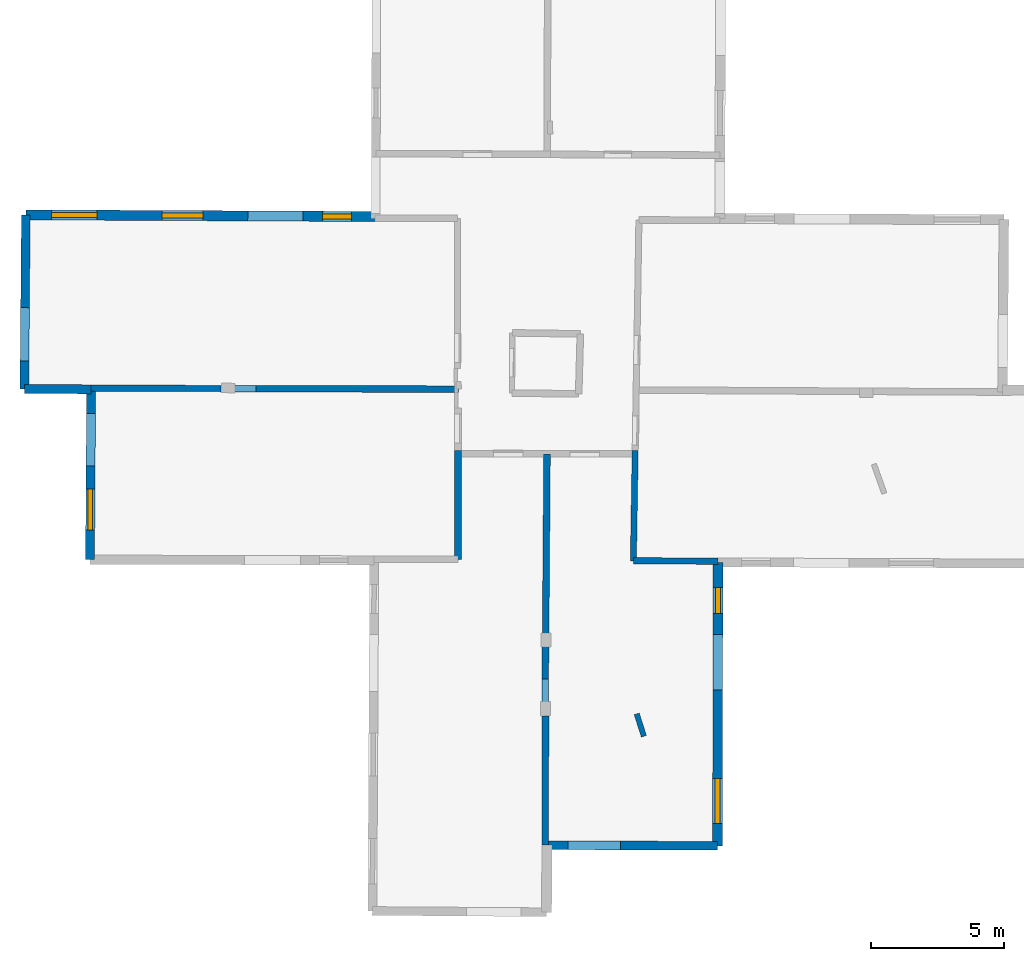
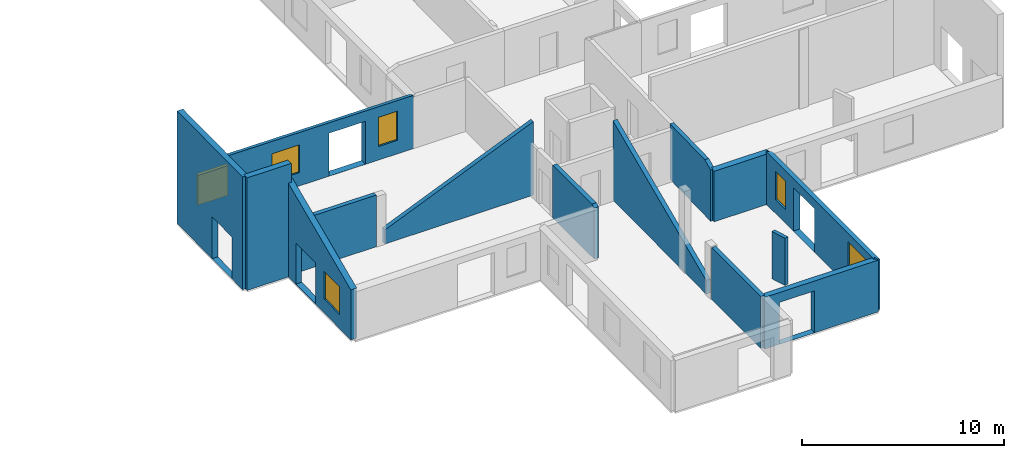
# One storey, part 2 of 10: 14 walls, 6 windows, 11 openings.
"""IFC2X3 building model written with IfcOpenShell, lengths in metres."""

from ifc_helpers import new_model, entity, si_unit, converted_unit, derived_unit, direction, frame, frame_2d, origin, origin_2d_with_axis, place, context, subcontext, project, spatial, polyline, rectangle, outline, extrude, clip, halfspace, source, transform, mapped, material, layer, layer_set, layer_usage, type_object, type_shapes, element, fill, save


model = new_model("IFC2X3")

# Units and contexts
model_context = context("Model", 3, precision=1e-05, world=origin(), true_north=direction((0.0, 1.0)))
body_context = subcontext(model_context, "Body", "Model", "MODEL_VIEW")
ifc_project = project(units=[si_unit("LENGTHUNIT", "METRE"), si_unit("AREAUNIT", "SQUARE_METRE"), si_unit("VOLUMEUNIT", "CUBIC_METRE"), converted_unit("PLANEANGLEUNIT", "DEGREE", entity("IfcRatioMeasure", 0.0174532925199433), si_unit("PLANEANGLEUNIT", "RADIAN"), dimensions=[0, 0, 0, 0, 0, 0, 0]), si_unit("MASSUNIT", "GRAM", prefix="KILO"), derived_unit("MASSDENSITYUNIT", [(si_unit("MASSUNIT", "GRAM", prefix="KILO"), 1), (si_unit("LENGTHUNIT", "METRE"), -3)]), derived_unit("MOMENTOFINERTIAUNIT", [(si_unit("LENGTHUNIT", "METRE"), 4)]), si_unit("TIMEUNIT", "SECOND"), si_unit("FREQUENCYUNIT", "HERTZ"), si_unit("THERMODYNAMICTEMPERATUREUNIT", "DEGREE_CELSIUS"), derived_unit("THERMALTRANSMITTANCEUNIT", [(si_unit("MASSUNIT", "GRAM", prefix="KILO"), 1), (si_unit("THERMODYNAMICTEMPERATUREUNIT", "KELVIN"), -1), (si_unit("TIMEUNIT", "SECOND"), -3)]), derived_unit("VOLUMETRICFLOWRATEUNIT", [(si_unit("LENGTHUNIT", "METRE"), 3), (si_unit("TIMEUNIT", "SECOND"), -1)]), si_unit("ELECTRICCURRENTUNIT", "AMPERE"), si_unit("ELECTRICVOLTAGEUNIT", "VOLT"), si_unit("POWERUNIT", "WATT"), si_unit("FORCEUNIT", "NEWTON", prefix="KILO"), si_unit("ILLUMINANCEUNIT", "LUX"), si_unit("LUMINOUSFLUXUNIT", "LUMEN"), si_unit("LUMINOUSINTENSITYUNIT", "CANDELA"), derived_unit("USERDEFINED", [(si_unit("MASSUNIT", "GRAM", prefix="KILO"), -1), (si_unit("LENGTHUNIT", "METRE"), -2), (si_unit("TIMEUNIT", "SECOND"), 3), (si_unit("LUMINOUSFLUXUNIT", "LUMEN"), 1)]), derived_unit("LINEARVELOCITYUNIT", [(si_unit("LENGTHUNIT", "METRE"), 1), (si_unit("TIMEUNIT", "SECOND"), -1)]), si_unit("PRESSUREUNIT", "PASCAL"), derived_unit("USERDEFINED", [(si_unit("LENGTHUNIT", "METRE"), -2), (si_unit("MASSUNIT", "GRAM", prefix="KILO"), 1), (si_unit("TIMEUNIT", "SECOND"), -2)]), derived_unit("LINEARFORCEUNIT", [(si_unit("MASSUNIT", "GRAM", prefix="KILO"), 1), (si_unit("LENGTHUNIT", "METRE"), 1), (si_unit("TIMEUNIT", "SECOND"), -2), (si_unit("LENGTHUNIT", "METRE"), -1)]), derived_unit("PLANARFORCEUNIT", [(si_unit("MASSUNIT", "GRAM", prefix="KILO"), 1), (si_unit("LENGTHUNIT", "METRE"), 1), (si_unit("TIMEUNIT", "SECOND"), -2), (si_unit("LENGTHUNIT", "METRE"), -2)])], contexts=[model_context])

# Site, building, storey
placement = place(None, origin())
site = spatial("IfcSite", under=ifc_project, at=placement, CompositionType="ELEMENT")
building = spatial("IfcBuilding", under=site, at=placement, CompositionType="ELEMENT")
storey_placement = place(placement, frame((0.0, 0.0, 15.2695512771606)))
storey = spatial("IfcBuildingStorey", under=building, at=storey_placement, Name="Level 6", CompositionType="ELEMENT", Elevation=15.2695512771606)

# Walls
ifc_material_1 = material(Name="Default wall")
ifc_layer_1 = layer(ifc_material_1, 0.25)
ifc_layer_set_1 = layer_set([ifc_layer_1], Name="wall_thickness_0.2500")
ifc_layer_usage_1 = layer_usage(ifc_layer_set_1, "AXIS2", "POSITIVE", -0.125)
wall_type_1 = type_object("IfcWallType", Name="wall_thickness_0.2500", PredefinedType="STANDARD", material=ifc_layer_set_1)
wall_1_placement = place(storey_placement, frame((-5.60322072614438, 19.4659078051316, 0.0), z_axis=(0.0, 0.0, 1.0), x_axis=(0.999998036302334, -0.00198176473781889, 0.0)))
element("IfcWallStandardCase", 1, at=wall_1_placement, inside=storey, type_object=wall_type_1, material=ifc_layer_usage_1, Name="Wall:173", ObjectType="Wall", context=body_context, shape_type="Clipping", body=[
    clip(clip(extrude(outline(polyline([(8.46955627398187, -0.125), (8.46955627398187, 0.125), (0.0, 0.125), (0.0, -0.125), (8.46955627398187, -0.125)])), origin(), (0.0, 0.0, 1.0), 4.78644847869873), halfspace(frame((-6.43011857681131, 0.115278729756931, 5.79555813666937), z_axis=(-0.00352248003647162, -0.389125563746589, 0.921177989192801), x_axis=(0.999969252007901, -0.00782471946601445, 0.000518463148508191)), False)), halfspace(frame((4.22868366465691, 56.3863865826198, 2.60439273833051), z_axis=(-0.389900245651926, 0.000641740330405517, 0.920856876289642), x_axis=(0.920848491571147, -0.00372210027699557, 0.389902810378011)), False)),
])
wall_2_placement = place(storey_placement, frame((6.2012203294045, 17.0091506300142, 0.0), z_axis=(0.0, 0.0, 1.0), x_axis=(-0.0076227098503879, -0.999970946725222, 0.0)))
element("IfcWallStandardCase", 2, at=wall_2_placement, inside=storey, type_object=wall_type_1, material=ifc_layer_usage_1, Name="Wall:174", ObjectType="Wall", context=body_context, shape_type="Clipping", body=[
    clip(clip(extrude(outline(polyline([(9.36351657435874, -0.125), (9.36351657435874, 0.125), (0.0, 0.125), (0.0, -0.125), (9.36351657435874, -0.125)])), origin(), (0.0, 0.0, 1.0), 4.78644847869873), halfspace(frame((-2.44570864484468, -18.2534918013209, 5.79555813666937), z_axis=(0.389139242831793, -0.00132737146518421, 0.921177989192801), x_axis=(0.00218378069925153, 0.999997481145738, 0.000518463148508191)), False)), halfspace(frame((-60.2761441511254, 6.15601547085556, 3.16730048752112), z_axis=(-0.00107289024517575, 0.390498648861477, 0.920602875372374), x_axis=(0.675450115714513, -0.678574807732, 0.288623234499112)), False)),
])
wall_3_placement = place(storey_placement, frame((2.84131288517312, 17.1376290023504, 0.0), z_axis=(0.0, 0.0, 1.0), x_axis=(-4.22260261359946e-05, -0.999999999108481, 0.0)))
element("IfcWallStandardCase", 3, at=wall_3_placement, inside=storey, type_object=wall_type_1, material=ifc_layer_usage_1, Name="Wall:193", ObjectType="Wall", context=body_context, shape_type="Clipping", body=[
    clip(clip(extrude(outline(polyline([(4.11046791443116, -0.125), (4.11046791443116, 0.125), (0.0, 0.125), (0.0, -0.125), (4.11046791443116, -0.125)])), origin(), (0.0, 0.0, 1.0), 3.19044971466064), halfspace(frame((-2.4556721989591, -14.8745148125377, 5.79555813666937), z_axis=(0.389117999850863, -0.00427719753718421, 0.921177989192801), x_axis=(0.00976418390435561, 0.999952194811655, 0.000518463148508191)), False)), halfspace(frame((-58.7060010506614, -4.10659262269018, 2.60439273833051), z_axis=(-0.00139796577512948, -0.389898267605507, 0.920856876289642), x_axis=(0.00550811464779624, 0.920839540382773, 0.389902810378011)), False)),
])
wall_4_placement = place(storey_placement, frame((6.14555115335482, 7.12793347812599, 0.0), z_axis=(0.0, 0.0, 1.0), x_axis=(-0.00290716654806058, -0.999995774182402, 0.0)))
element("IfcWallStandardCase", 4, at=wall_4_placement, inside=storey, type_object=wall_type_1, material=ifc_layer_usage_1, Name="Wall:211", ObjectType="Wall", context=body_context, shape_type="Clipping", body=[
    clip(clip(extrude(outline(polyline([(4.88028895855337, -0.125), (4.88028895855337, 0.125), (0.0, 0.125), (0.0, -0.125), (4.88028895855337, -0.125)])), origin(), (0.0, 0.0, 1.0), 3.13044834136963), halfspace(frame((-70.1277819279259, 6.46712753945122, 3.16730048752112), z_axis=(0.000768555375702521, 0.390499366425544, 0.920602875372374), x_axis=(0.672242721388589, -0.681752412571701, 0.288623234499112)), False)), halfspace(frame((8.50597192338586, -7.41572161016197, 2.68738778709587), z_axis=(0.392743265143468, 0.00104823852077653, 0.919647556882772), x_axis=(-0.00266901920406505, 0.999996438161901, 0.0)), False)),
])

# Wall, opening
ifc_layer_2 = layer(ifc_material_1, 0.330000013113022)
ifc_layer_set_2 = layer_set([ifc_layer_2], Name="wall_thickness_0.3300")
ifc_layer_usage_2 = layer_usage(ifc_layer_set_2, "AXIS2", "POSITIVE", -0.165000006556511)
wall_type_2 = type_object("IfcWallType", Name="wall_thickness_0.3300", PredefinedType="STANDARD", material=ifc_layer_set_2)
wall_5_placement = place(storey_placement, frame((-13.4578742324254, 26.0234582509722, 0.0), z_axis=(0.0, 0.0, 1.0), x_axis=(-0.008312792533583, -0.999965448143231, 0.0)))
wall_5 = element("IfcWallStandardCase", 5, at=wall_5_placement, inside=storey, type_object=wall_type_2, material=ifc_layer_usage_2, Name="Wall:214", ObjectType="Wall", context=body_context, shape_type="SweptSolid", body=[
    extrude(outline(polyline([(6.57275021778953, -0.165000006556511), (6.57275021778953, 0.165000006556511), (0.0, 0.165000006556511), (0.0, -0.165000006556511), (6.57275021778953, -0.165000006556511)])), origin(), (0.0, 0.0, 1.0), 6.8064489364624),
])
opening_1_placement = place(wall_5_placement, frame((3.50430961809442, -0.165000006556511, 0.00544929504394531)))
element("IfcOpeningElement", 6, at=opening_1_placement, cuts=wall_5, Name="Opening : 2015 x 2525 : 190", ObjectType="Opening", context=body_context, shape_type="SweptSolid", body=[
    extrude(rectangle(XDim=2.015, YDim=2.525, at=frame_2d((1.2625, 1.0075), x_axis=(0.0, 1.0))), frame((0.0, 0.0, 0.0), z_axis=(0.0, 1.0, 0.0), x_axis=(0.0, 0.0, 1.0)), (0.0, 0.0, 1.0), 0.330000013113022),
])

wall_6_placement = place(storey_placement, frame((6.13136342435919, 2.24766486243681, 0.0), z_axis=(0.0, 0.0, 1.0), x_axis=(0.999992104409415, -0.00397380407547253, 0.0)))
wall_6 = element("IfcWallStandardCase", 7, at=wall_6_placement, inside=storey, type_object=wall_type_2, material=ifc_layer_usage_2, Name="Wall:228", ObjectType="Wall", context=body_context, shape_type="Clipping", body=[
    clip(clip(extrude(outline(polyline([(6.50169642292887, -0.165000006556511), (6.50169642292887, 0.165000006556511), (0.0, 0.165000006556511), (0.0, -0.165000006556511), (6.50169642292887, -0.165000006556511)])), origin(), (0.0, 0.0, 1.0), 3.13044834136963), halfspace(frame((6.38711689020082, 75.0149266178325, 3.16730048752112), z_axis=(0.390499964059042, -0.000352031253883832, 0.920602875372374), x_axis=(-0.681034981290926, -0.672969525881625, 0.288623234499112)), False)), halfspace(frame((-7.41185016469238, -3.63359055495066, 2.68738778709587), z_axis=(0.00146715504949101, -0.392741923628748, 0.919647556882772), x_axis=(0.999993022406897, 0.00373565757518009, 0.0)), False)),
])
opening_2_placement = place(wall_6_placement, frame((0.85579021385481, -0.165000006556511, 0.00544929504394531)))
element("IfcOpeningElement", 8, at=opening_2_placement, cuts=wall_6, Name="Opening : 1990 x 2530 : 203", ObjectType="Opening", context=body_context, shape_type="SweptSolid", body=[
    extrude(rectangle(XDim=1.99, YDim=2.53, at=frame_2d((1.265, 0.995), x_axis=(0.0, 1.0))), frame((0.0, 0.0, 0.0), z_axis=(0.0, 1.0, 0.0), x_axis=(0.0, 0.0, 1.0)), (0.0, 0.0, 1.0), 0.330000013113022),
])

# Walls
ifc_layer_3 = layer(ifc_material_1, 0.2)
ifc_layer_set_3 = layer_set([ifc_layer_3], Name="wall_thickness_0.2000")
ifc_layer_usage_3 = layer_usage(ifc_layer_set_3, "AXIS2", "POSITIVE", -0.1)
wall_type_3 = type_object("IfcWallType", Name="wall_thickness_0.2000", PredefinedType="STANDARD", material=ifc_layer_set_3)
wall_7_placement = place(storey_placement, frame((9.58418474775644, 7.19910614782844, 0.0), z_axis=(0.0, 0.0, 1.0), x_axis=(0.304531341624548, -0.95250231599107, 0.0)))
element("IfcWallStandardCase", 9, at=wall_7_placement, inside=storey, type_object=wall_type_3, material=ifc_layer_usage_3, Name="Wall:185", ObjectType="Wall", context=body_context, shape_type="Clipping", body=[
    clip(extrude(outline(polyline([(0.885000104512441, -0.1), (0.885000104512441, 0.1), (0.0, 0.1), (0.0, -0.1), (0.885000104512441, -0.1)])), origin(), (0.0, 0.0, 1.0), 2.86044979095459), halfspace(frame((-65.726543522396, 24.4074285666055, 3.16730048752112), z_axis=(0.120731485797975, 0.371368084510678, 0.920602875372374), x_axis=(0.43021296258131, -0.855344045010125, 0.288623234499112)), False)),
])
ifc_layer_4 = layer(ifc_material_1, 0.239999994635582)
ifc_layer_set_4 = layer_set([ifc_layer_4], Name="wall_thickness_0.2400")
ifc_layer_usage_4 = layer_usage(ifc_layer_set_4, "AXIS2", "POSITIVE", -0.119999997317791)
wall_type_4 = type_object("IfcWallType", Name="wall_thickness_0.2400", PredefinedType="STANDARD", material=ifc_layer_set_4)
wall_8_placement = place(storey_placement, frame((-10.9951521356064, 19.4894429533561, 0.0), z_axis=(0.0, 0.0, 1.0), x_axis=(0.999992189033075, -0.00395245149727228, 0.0)))
element("IfcWallStandardCase", 10, at=wall_8_placement, inside=storey, type_object=wall_type_4, material=ifc_layer_usage_4, Name="Wall:176", ObjectType="Wall", context=body_context, shape_type="Clipping", body=[
    clip(extrude(outline(polyline([(4.90729064239144, -0.119999997317791), (4.90729064239144, 0.119999997317791), (0.0, 0.119999997317791), (0.0, -0.119999997317791), (4.90729064239144, -0.119999997317791)])), origin(), (0.0, 0.0, 1.0), 3.13044834136963), halfspace(frame((-1.03835095503705, 0.100383089717447, 5.79555813666937), z_axis=(-0.00275562559690647, -0.389131749866646, 0.921177989192801), x_axis=(0.999982730378801, -0.00585407038918155, 0.000518463148508191)), False)),
])
wall_9_placement = place(storey_placement, frame((9.45862319725223, 12.9733351814167, 0.0), z_axis=(0.0, 0.0, 1.0), x_axis=(0.999991825873343, -0.00404328906936174, 0.0)))
element("IfcWallStandardCase", 11, at=wall_9_placement, inside=storey, type_object=wall_type_4, material=ifc_layer_usage_4, Name="Wall:225", ObjectType="Wall", context=body_context, shape_type="Clipping", body=[
    clip(clip(extrude(outline(polyline([(3.18961557274893, -0.119999997317791), (3.18961557274893, 0.119999997317791), (0.0, 0.119999997317791), (0.0, -0.119999997317791), (3.18961557274893, -0.119999997317791)])), origin(), (0.0, 0.0, 1.0), 3.25044918060303), halfspace(frame((-21.5183147178195, 6.53364274948854, 5.79555813666937), z_axis=(-0.00272027751970835, -0.389131998577506, 0.921177989192801), x_axis=(0.999983258026864, -0.00576323363584042, 0.000518463148508191)), False)), halfspace(frame((3.09803883130094, 64.2763345300181, 3.16730048752112), z_axis=(0.390499987577414, -0.000324897147431658, 0.920602875372374), x_axis=(-0.680988217987764, -0.673016846348678, 0.288623234499112)), False)),
])

# Wall, openings, windows
ifc_layer_5 = layer(ifc_material_1, 0.379999995231628)
ifc_layer_set_5 = layer_set([ifc_layer_5], Name="wall_thickness_0.3800")
ifc_layer_usage_5 = layer_usage(ifc_layer_set_5, "AXIS2", "POSITIVE", -0.189999997615814)
wall_type_5 = type_object("IfcWallType", Name="wall_thickness_0.3800", PredefinedType="STANDARD", material=ifc_layer_set_5)
wall_10_placement = place(storey_placement, frame((-13.4578753216483, 26.0234593808512, 0.0), z_axis=(0.0, 0.0, 1.0), x_axis=(0.999988048187232, -0.00488911880515557, 0.0)))
wall_10 = element("IfcWallStandardCase", 12, at=wall_10_placement, inside=storey, type_object=wall_type_5, material=ifc_layer_usage_5, Name="Wall:200", ObjectType="Wall", context=body_context, shape_type="Clipping", body=[
    clip(extrude(outline(polyline([(13.1935070477457, -0.189999997615814), (13.1935070477457, 0.189999997615814), (0.0, 0.189999997615814), (0.0, -0.189999997615814), (13.1935070477457, -0.189999997615814)])), origin(), (0.0, 0.0, 1.0), 5.12044811248779), halfspace(frame((37.8703720846611, -6.60155196065922, 5.89042703244326), z_axis=(0.00143596223778616, 0.389133506980697, 0.921180249330909), x_axis=(-0.999987775382126, 0.00491734540622382, -0.000518459702406836)), False)),
])
opening_3_placement = place(wall_10_placement, frame((8.37132065482613, -0.189999997615814, 0.00544929504394531)))
element("IfcOpeningElement", 13, at=opening_3_placement, cuts=wall_10, Name="Opening : 2080 x 2595 : 180", ObjectType="Opening", context=body_context, shape_type="SweptSolid", body=[
    extrude(rectangle(XDim=2.08, YDim=2.595, at=frame_2d((1.2975, 1.04), x_axis=(0.0, 1.0))), frame((0.0, 0.0, 0.0), z_axis=(0.0, 1.0, 0.0), x_axis=(0.0, 0.0, 1.0)), (0.0, 0.0, 1.0), 0.379999995231628),
])
opening_4_placement = place(wall_10_placement, frame((0.976321455521542, -0.189999997615814, 0.765448570251465)))
opening_4 = element("IfcOpeningElement", 14, at=opening_4_placement, cuts=wall_10, Name="Opening : 1710 x 1800 : 181", ObjectType="Opening", context=body_context, shape_type="SweptSolid", body=[
    extrude(rectangle(XDim=1.71, YDim=1.8, at=frame_2d((0.9, 0.855), x_axis=(0.0, 1.0))), frame((0.0, 0.0, 0.0), z_axis=(0.0, 1.0, 0.0), x_axis=(0.0, 0.0, 1.0)), (0.0, 0.0, 1.0), 0.379999995231628),
])
opening_5_placement = place(wall_10_placement, frame((11.1963194156907, -0.189999997615814, 0.820448875427246)))
opening_5 = element("IfcOpeningElement", 15, at=opening_5_placement, cuts=wall_10, Name="Opening : 1085 x 1765 : 182", ObjectType="Opening", context=body_context, shape_type="SweptSolid", body=[
    extrude(rectangle(XDim=1.085, YDim=1.765, at=frame_2d((0.8825, 0.5425), x_axis=(0.0, 1.0))), frame((0.0, 0.0, 0.0), z_axis=(0.0, 1.0, 0.0), x_axis=(0.0, 0.0, 1.0)), (0.0, 0.0, 1.0), 0.379999995231628),
])
opening_6_placement = place(wall_10_placement, frame((5.12835624890828, -0.189999997615814, 0.805449485778809)))
opening_6 = element("IfcOpeningElement", 16, at=opening_6_placement, cuts=wall_10, Name="Opening : 1560 x 1680 : 183", ObjectType="Opening", context=body_context, shape_type="SweptSolid", body=[
    extrude(rectangle(XDim=1.56, YDim=1.68, at=frame_2d((0.84, 0.78), x_axis=(0.0, 1.0))), frame((0.0, 0.0, 0.0), z_axis=(0.0, 1.0, 0.0), x_axis=(0.0, 0.0, 1.0)), (0.0, 0.0, 1.0), 0.379999995231628),
])
ifc_material_2 = material(Name="Window Default")
window_style_1 = type_object("IfcWindowStyle", Name="Window : 1710 x 1800mm", ConstructionType="NOTDEFINED", OperationType="NOTDEFINED", ParameterTakesPrecedence=False, Sizeable=False, material=ifc_material_2)
shared_shape_1 = source(origin(), body_context, "Body", "SweptSolid", [
    extrude(rectangle(XDim=0.189999997615814, YDim=1.71, at=origin_2d_with_axis()), frame((0.855, 0.189999997615814, 0.0), z_axis=(0.0, 0.0, 1.0), x_axis=(0.0, 1.0, 0.0)), (0.0, 0.0, 1.0), 1.8),
])
type_shapes(window_style_1, [shared_shape_1])
window_1_placement = place(opening_4_placement, origin())
window_1 = element("IfcWindow", 17, at=window_1_placement, inside=storey, type_object=window_style_1, Name="Window : 1710 x 1800mm : 99", ObjectType="Window : 1710 x 1800mm", OverallHeight=1.8, OverallWidth=1.71, context=body_context, shape_type="MappedRepresentation", body=[
    mapped(shared_shape_1, transform((0.0, 0.0, 0.0), scale=1.0)),
])
fill(opening_4, window_1)
window_style_2 = type_object("IfcWindowStyle", Name="Window : 1085 x 1765mm", ConstructionType="NOTDEFINED", OperationType="NOTDEFINED", ParameterTakesPrecedence=False, Sizeable=False, material=ifc_material_2)
shared_shape_2 = source(origin(), body_context, "Body", "SweptSolid", [
    extrude(rectangle(XDim=0.189999997615814, YDim=1.085, at=origin_2d_with_axis()), frame((0.5425, 0.189999997615814, 0.0), z_axis=(0.0, 0.0, 1.0), x_axis=(0.0, 1.0, 0.0)), (0.0, 0.0, 1.0), 1.765),
])
type_shapes(window_style_2, [shared_shape_2])
window_2_placement = place(opening_5_placement, origin())
window_2 = element("IfcWindow", 18, at=window_2_placement, inside=storey, type_object=window_style_2, Name="Window : 1085 x 1765mm : 100", ObjectType="Window : 1085 x 1765mm", OverallHeight=1.765, OverallWidth=1.085, context=body_context, shape_type="MappedRepresentation", body=[
    mapped(shared_shape_2, transform((0.0, 0.0, 0.0), scale=1.0)),
])
fill(opening_5, window_2)
window_style_3 = type_object("IfcWindowStyle", Name="Window : 1560 x 1680mm", ConstructionType="NOTDEFINED", OperationType="NOTDEFINED", ParameterTakesPrecedence=False, Sizeable=False, material=ifc_material_2)
shared_shape_3 = source(origin(), body_context, "Body", "SweptSolid", [
    extrude(rectangle(XDim=0.189999997615814, YDim=1.56, at=origin_2d_with_axis()), frame((0.78, 0.189999997615814, 0.0), z_axis=(0.0, 0.0, 1.0), x_axis=(0.0, 1.0, 0.0)), (0.0, 0.0, 1.0), 1.68),
])
type_shapes(window_style_3, [shared_shape_3])
window_3_placement = place(opening_6_placement, origin())
window_3 = element("IfcWindow", 19, at=window_3_placement, inside=storey, type_object=window_style_3, Name="Window : 1560 x 1680mm : 101", ObjectType="Window : 1560 x 1680mm", OverallHeight=1.68, OverallWidth=1.56, context=body_context, shape_type="MappedRepresentation", body=[
    mapped(shared_shape_3, transform((0.0, 0.0, 0.0), scale=1.0)),
])
fill(opening_6, window_3)

# Wall, openings, window
ifc_layer_6 = layer(ifc_material_1, 0.340000003576279)
ifc_layer_set_6 = layer_set([ifc_layer_6], Name="wall_thickness_0.3400")
ifc_layer_usage_6 = layer_usage(ifc_layer_set_6, "AXIS2", "POSITIVE", -0.170000001788139)
wall_type_6 = type_object("IfcWallType", Name="wall_thickness_0.3400", PredefinedType="STANDARD", material=ifc_layer_set_6)
wall_11_placement = place(storey_placement, frame((-10.9951510903459, 19.4894404381542, 0.0), z_axis=(0.0, 0.0, 1.0), x_axis=(-0.00624121809690258, -0.999980523408665, 0.0)))
wall_11 = element("IfcWallStandardCase", 20, at=wall_11_placement, inside=storey, type_object=wall_type_6, material=ifc_layer_usage_6, Name="Wall:154", ObjectType="Wall", context=body_context, shape_type="Clipping", body=[
    clip(extrude(outline(polyline([(6.47378751004322, -0.170000001788139), (6.47378751004322, 0.170000001788139), (0.0, 0.170000001788139), (0.0, -0.170000001788139), (6.47378751004322, -0.170000001788139)])), origin(), (0.0, 0.0, 1.0), 5.83044910430908), halfspace(frame((-0.0980087631161872, -1.03857905252509, 5.79555813666937), z_axis=(0.389137037677684, -0.00186497564184208, 0.921177989192801), x_axis=(0.0035652997523032, 0.999993509895759, 0.000518463148508191)), False)),
])
opening_7_placement = place(wall_11_placement, frame((0.958041773299851, -0.170000001788139, 0.0204496383666992)))
element("IfcOpeningElement", 21, at=opening_7_placement, cuts=wall_11, Name="Opening : 1980 x 2490 : 145", ObjectType="Opening", context=body_context, shape_type="SweptSolid", body=[
    extrude(rectangle(XDim=1.98, YDim=2.49, at=frame_2d((1.245, 0.99), x_axis=(0.0, 1.0))), frame((0.0, 0.0, 0.0), z_axis=(0.0, 1.0, 0.0), x_axis=(0.0, 0.0, 1.0)), (0.0, 0.0, 1.0), 0.340000003576279),
])
opening_8_placement = place(wall_11_placement, frame((3.80804330051898, -0.170000001788139, 0.84544849395752)))
opening_8 = element("IfcOpeningElement", 22, at=opening_8_placement, cuts=wall_11, Name="Opening : 1550 x 1675 : 146", ObjectType="Opening", context=body_context, shape_type="SweptSolid", body=[
    extrude(rectangle(XDim=1.55, YDim=1.675, at=frame_2d((0.8375, 0.775), x_axis=(0.0, 1.0))), frame((0.0, 0.0, 0.0), z_axis=(0.0, 1.0, 0.0), x_axis=(0.0, 0.0, 1.0)), (0.0, 0.0, 1.0), 0.340000003576279),
])
window_style_4 = type_object("IfcWindowStyle", Name="Window : 1550 x 1675mm", ConstructionType="NOTDEFINED", OperationType="NOTDEFINED", ParameterTakesPrecedence=False, Sizeable=False, material=ifc_material_2)
shared_shape_4 = source(origin(), body_context, "Body", "SweptSolid", [
    extrude(rectangle(XDim=0.170000001788139, YDim=1.55, at=origin_2d_with_axis()), frame((0.775, 0.170000001788139, 0.0), z_axis=(0.0, 0.0, 1.0), x_axis=(0.0, 1.0, 0.0)), (0.0, 0.0, 1.0), 1.675),
])
type_shapes(window_style_4, [shared_shape_4])
window_4_placement = place(opening_8_placement, origin())
window_4 = element("IfcWindow", 23, at=window_4_placement, inside=storey, type_object=window_style_4, Name="Window : 1550 x 1675mm : 82", ObjectType="Window : 1550 x 1675mm", OverallHeight=1.675, OverallWidth=1.55, context=body_context, shape_type="MappedRepresentation", body=[
    mapped(shared_shape_4, transform((0.0, 0.0, 0.0), scale=1.0)),
])
fill(opening_8, window_4)

# Wall
wall_12_placement = place(storey_placement, frame((-13.5125120860506, 19.4509363870543, 0.0), z_axis=(0.0, 0.0, 1.0), x_axis=(0.999995234838731, -0.00308711837020969, 0.0)))
element("IfcWallStandardCase", 24, at=wall_12_placement, inside=storey, type_object=wall_type_6, material=ifc_layer_usage_6, Name="Wall:168", ObjectType="Wall", context=body_context, shape_type="SweptSolid", body=[
    extrude(outline(polyline([(2.51708467192669, -0.170000001788139), (2.51708467192669, 0.170000001788139), (0.0, 0.170000001788139), (0.0, -0.170000001788139), (2.51708467192669, -0.170000001788139)])), origin(), (0.0, 0.0, 1.0), 6.8064489364624),
])

# Wall, openings, windows
ifc_layer_7 = layer(ifc_material_1, 0.370000004768372)
ifc_layer_set_7 = layer_set([ifc_layer_7], Name="wall_thickness_0.3700")
ifc_layer_usage_7 = layer_usage(ifc_layer_set_7, "AXIS2", "POSITIVE", -0.185000002384186)
wall_type_7 = type_object("IfcWallType", Name="wall_thickness_0.3700", PredefinedType="STANDARD", material=ifc_layer_set_7)
wall_13_placement = place(storey_placement, frame((12.6481450730107, 12.9119685682253, 0.0), z_axis=(0.0, 0.0, 1.0), x_axis=(-0.00141594995255933, -0.999998997542363, 0.0)))
wall_13 = element("IfcWallStandardCase", 25, at=wall_13_placement, inside=storey, type_object=wall_type_7, material=ifc_layer_usage_7, Name="Wall:218", ObjectType="Wall", context=body_context, shape_type="Clipping", body=[
    clip(extrude(outline(polyline([(10.6901509637684, -0.185000002384186), (10.6901509637684, 0.185000002384186), (0.0, 0.185000002384186), (0.0, -0.185000002384186), (10.6901509637684, -0.185000002384186)])), origin(), (0.0, 0.0, 1.0), 3.19044971466064), halfspace(frame((-64.3248234078804, 0.0772987794405043, 3.16730048752112), z_axis=(0.00135087485545062, 0.390497786156646, 0.920602875372374), x_axis=(0.671225331338866, -0.682754116118168, 0.288623234499112)), False)),
])
opening_9_placement = place(wall_13_placement, frame((2.72273625366172, -0.185000002384186, 0.00544929504394531)))
element("IfcOpeningElement", 26, at=opening_9_placement, cuts=wall_13, Name="Opening : 2080 x 2620 : 193", ObjectType="Opening", context=body_context, shape_type="SweptSolid", body=[
    extrude(rectangle(XDim=2.08, YDim=2.62, at=frame_2d((1.31, 1.04), x_axis=(0.0, 1.0))), frame((0.0, 0.0, 0.0), z_axis=(0.0, 1.0, 0.0), x_axis=(0.0, 0.0, 1.0)), (0.0, 0.0, 1.0), 0.370000004768372),
])
opening_10_placement = place(wall_13_placement, frame((8.14273699457591, -0.185000002384186, 0.81044864654541)))
opening_10 = element("IfcOpeningElement", 27, at=opening_10_placement, cuts=wall_13, Name="Opening : 1710 x 1850 : 194", ObjectType="Opening", context=body_context, shape_type="SweptSolid", body=[
    extrude(rectangle(XDim=1.71, YDim=1.85, at=frame_2d((0.925, 0.855), x_axis=(0.0, 1.0))), frame((0.0, 0.0, 0.0), z_axis=(0.0, 1.0, 0.0), x_axis=(0.0, 0.0, 1.0)), (0.0, 0.0, 1.0), 0.370000004768372),
])
opening_11_placement = place(wall_13_placement, frame((0.939176574016933, -0.185000002384186, 0.840449333190918)))
opening_11 = element("IfcOpeningElement", 28, at=opening_11_placement, cuts=wall_13, Name="Opening : 990 x 1720 : 195", ObjectType="Opening", context=body_context, shape_type="SweptSolid", body=[
    extrude(rectangle(XDim=0.99, YDim=1.72, at=frame_2d((0.86, 0.495), x_axis=(0.0, 1.0))), frame((0.0, 0.0, 0.0), z_axis=(0.0, 1.0, 0.0), x_axis=(0.0, 0.0, 1.0)), (0.0, 0.0, 1.0), 0.370000004768372),
])
window_style_5 = type_object("IfcWindowStyle", Name="Window : 1710 x 1850mm", ConstructionType="NOTDEFINED", OperationType="NOTDEFINED", ParameterTakesPrecedence=False, Sizeable=False, material=ifc_material_2)
shared_shape_5 = source(origin(), body_context, "Body", "SweptSolid", [
    extrude(rectangle(XDim=0.185000002384186, YDim=1.71, at=origin_2d_with_axis()), frame((0.855, 0.185000002384186, 0.0), z_axis=(0.0, 0.0, 1.0), x_axis=(0.0, 1.0, 0.0)), (0.0, 0.0, 1.0), 1.85),
])
type_shapes(window_style_5, [shared_shape_5])
window_5_placement = place(opening_10_placement, origin())
window_5 = element("IfcWindow", 29, at=window_5_placement, inside=storey, type_object=window_style_5, Name="Window : 1710 x 1850mm : 104", ObjectType="Window : 1710 x 1850mm", OverallHeight=1.85, OverallWidth=1.71, context=body_context, shape_type="MappedRepresentation", body=[
    mapped(shared_shape_5, transform((0.0, 0.0, 0.0), scale=1.0)),
])
fill(opening_10, window_5)
window_style_6 = type_object("IfcWindowStyle", Name="Window : 990 x 1720mm", ConstructionType="NOTDEFINED", OperationType="NOTDEFINED", ParameterTakesPrecedence=False, Sizeable=False, material=ifc_material_2)
shared_shape_6 = source(origin(), body_context, "Body", "SweptSolid", [
    extrude(rectangle(XDim=0.185000002384186, YDim=0.99, at=origin_2d_with_axis()), frame((0.495, 0.185000002384186, 0.0), z_axis=(0.0, 0.0, 1.0), x_axis=(0.0, 1.0, 0.0)), (0.0, 0.0, 1.0), 1.72),
])
type_shapes(window_style_6, [shared_shape_6])
window_6_placement = place(opening_11_placement, origin())
window_6 = element("IfcWindow", 30, at=window_6_placement, inside=storey, type_object=window_style_6, Name="Window : 990 x 1720mm : 105", ObjectType="Window : 990 x 1720mm", OverallHeight=1.72, OverallWidth=0.99, context=body_context, shape_type="MappedRepresentation", body=[
    mapped(shared_shape_6, transform((0.0, 0.0, 0.0), scale=1.0)),
])
fill(opening_11, window_6)

# Wall
ifc_layer_8 = layer(ifc_material_1, 0.230000004172325)
ifc_layer_set_8 = layer_set([ifc_layer_8], Name="wall_thickness_0.2300")
ifc_layer_usage_8 = layer_usage(ifc_layer_set_8, "AXIS2", "POSITIVE", -0.115000002086163)
wall_type_8 = type_object("IfcWallType", Name="wall_thickness_0.2300", PredefinedType="STANDARD", material=ifc_layer_set_8)
wall_14_placement = place(storey_placement, frame((9.52599486140558, 17.1306780278168, 0.0), z_axis=(0.0, 0.0, 1.0), x_axis=(-0.0162028014513871, -0.999868725996131, 0.0)))
element("IfcWallStandardCase", 31, at=wall_14_placement, inside=storey, type_object=wall_type_8, material=ifc_layer_usage_8, Name="Wall:164", ObjectType="Wall", context=body_context, shape_type="Clipping", body=[
    clip(clip(extrude(outline(polyline([(4.15788968726781, -0.115000002086163), (4.15788968726781, 0.115000002086163), (0.0, 0.115000002086163), (0.0, -0.115000002086163), (4.15788968726781, -0.115000002086163)])), origin(), (0.0, 0.0, 1.0), 3.35544872283936), halfspace(frame((-2.11361019741547, -21.5961745049006, 5.79555813666937), z_axis=(0.389136306649962, 0.00201173396234472, 0.921177989192801), x_axis=(-0.00639689960177468, 0.999979405223652, 0.000518463148508191)), False)), halfspace(frame((-60.1513654652684, 2.31621307110974, 3.16730048752112), z_axis=(-0.00442357185759786, 0.390475066896899, 0.920602875372374), x_axis=(0.681247843150075, -0.672754044737481, 0.288623234499112)), False)),
])

save(model, "model.ifc")
